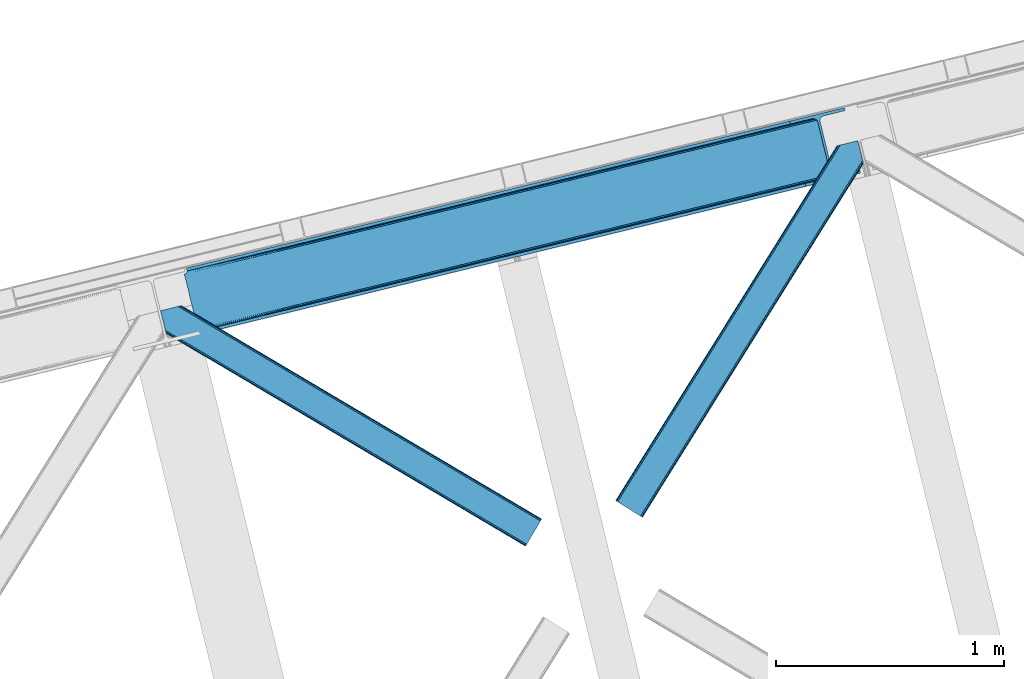
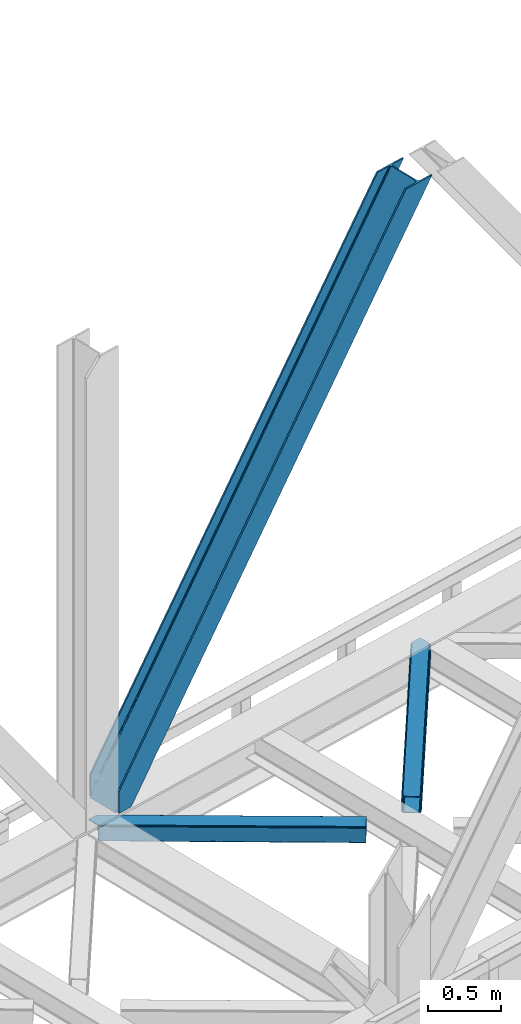
# One storey, part 75 of 92: 3 members.
"""IFC4 building model written with IfcOpenShell, lengths in millimetres."""

from ifc_helpers import new_model, entity, si_unit, converted_unit, derived_unit, direction, frame, origin, place, context, subcontext, project, spatial, triangles, type_object, element, save


model = new_model("IFC4")

# Units and contexts
model_context = context("Model", 3, precision=0.01, world=origin(), true_north=direction((6.12303176911189e-17, 1.0)))
plan_context = context("Plan", 3, precision=0.01, world=origin(), true_north=direction((6.12303176911189e-17, 1.0)))
body_context = subcontext(model_context, "Body", "Model", "MODEL_VIEW")
ifc_project = project(units=[si_unit("LENGTHUNIT", "METRE", prefix="MILLI"), si_unit("AREAUNIT", "SQUARE_METRE"), si_unit("VOLUMEUNIT", "CUBIC_METRE"), converted_unit("PLANEANGLEUNIT", "DEGREE", entity("IfcRatioMeasure", 0.0174532925199433), si_unit("PLANEANGLEUNIT", "RADIAN"), dimensions=[0, 0, 0, 0, 0, 0, 0]), si_unit("MASSUNIT", "GRAM", prefix="KILO"), derived_unit("MASSDENSITYUNIT", [(si_unit("MASSUNIT", "GRAM", prefix="KILO"), 1), (si_unit("LENGTHUNIT", "METRE"), -3)]), derived_unit("MOMENTOFINERTIAUNIT", [(si_unit("LENGTHUNIT", "METRE"), 4)]), si_unit("TIMEUNIT", "SECOND"), si_unit("FREQUENCYUNIT", "HERTZ"), si_unit("THERMODYNAMICTEMPERATUREUNIT", "DEGREE_CELSIUS"), derived_unit("THERMALTRANSMITTANCEUNIT", [(si_unit("MASSUNIT", "GRAM", prefix="KILO"), 1), (si_unit("THERMODYNAMICTEMPERATUREUNIT", "KELVIN"), -1), (si_unit("TIMEUNIT", "SECOND"), -3)]), derived_unit("VOLUMETRICFLOWRATEUNIT", [(si_unit("LENGTHUNIT", "METRE"), 3), (si_unit("TIMEUNIT", "SECOND"), -1)]), derived_unit("MASSFLOWRATEUNIT", [(si_unit("MASSUNIT", "GRAM", prefix="KILO"), 1), (si_unit("TIMEUNIT", "SECOND"), -1)]), derived_unit("ROTATIONALFREQUENCYUNIT", [(si_unit("TIMEUNIT", "SECOND"), -1)]), si_unit("ELECTRICCURRENTUNIT", "AMPERE"), si_unit("ELECTRICVOLTAGEUNIT", "VOLT"), si_unit("POWERUNIT", "WATT"), si_unit("FORCEUNIT", "NEWTON", prefix="KILO"), si_unit("ILLUMINANCEUNIT", "LUX"), si_unit("LUMINOUSFLUXUNIT", "LUMEN"), si_unit("LUMINOUSINTENSITYUNIT", "CANDELA"), derived_unit("USERDEFINED", [(si_unit("MASSUNIT", "GRAM", prefix="KILO"), -1), (si_unit("LENGTHUNIT", "METRE"), -2), (si_unit("TIMEUNIT", "SECOND"), 3), (si_unit("LUMINOUSFLUXUNIT", "LUMEN"), 1)]), derived_unit("LINEARVELOCITYUNIT", [(si_unit("LENGTHUNIT", "METRE"), 1), (si_unit("TIMEUNIT", "SECOND"), -1)]), si_unit("PRESSUREUNIT", "PASCAL"), derived_unit("USERDEFINED", [(si_unit("LENGTHUNIT", "METRE"), -2), (si_unit("MASSUNIT", "GRAM", prefix="KILO"), 1), (si_unit("TIMEUNIT", "SECOND"), -2)]), derived_unit("LINEARFORCEUNIT", [(si_unit("MASSUNIT", "GRAM", prefix="KILO"), 1), (si_unit("LENGTHUNIT", "METRE"), 1), (si_unit("TIMEUNIT", "SECOND"), -2), (si_unit("LENGTHUNIT", "METRE"), -1)]), derived_unit("PLANARFORCEUNIT", [(si_unit("MASSUNIT", "GRAM", prefix="KILO"), 1), (si_unit("LENGTHUNIT", "METRE"), 1), (si_unit("TIMEUNIT", "SECOND"), -2), (si_unit("LENGTHUNIT", "METRE"), -2)])], contexts=[model_context, plan_context])

# Site, building, storey
site_placement = place(None, origin())
site = spatial("IfcSite", under=ifc_project, at=site_placement, CompositionType="ELEMENT")
building_placement = place(site_placement, origin())
building = spatial("IfcBuilding", under=site, at=building_placement, CompositionType="ELEMENT")
storey_placement = place(building_placement, frame((0.0, 0.0, 15900.0)))
storey = spatial("IfcBuildingStorey", under=building, at=storey_placement, Name="05", CompositionType="ELEMENT", Elevation=15900.0)

# Members
member_type_1 = type_object("IfcMemberType", PredefinedType="BRACE")
member_1_placement = place(storey_placement, frame((-17772.45, 16327.86, 3695.0)))
element("IfcMember", 1, at=member_1_placement, inside=storey, type_object=member_type_1, ObjectType="Steel Vertical Brace", PredefinedType="BRACE", context=body_context, shape_type="Tessellation", body=[
    triangles([(58.5487518310547, 26.6239562988285, 0.0), (60.4428222656243, 18.8523376464855, 0.0), (59.1045318603501, 19.6697296142574, 0.80925292968459), (58.9696563720681, 18.4930572509766, 1.10690917968532), (64.089111328125, 19.7406555175785, 8.31577148437282), (64.089111328125, 19.7406555175785, 0.0), (522.90412902832, 126.715521240234, 658.855133056641), (68.377221679686, 19.9243652343757, 14.8293273925774), (72.4072082519524, 18.4523620605469, 22.4381652832017), (524.58542175293, 133.136059570314, 656.552947998047), (73.9838562011719, 17.2861541748043, 26.4425720214822), (2834.75371398926, 696.263314819336, 3911.00081176758), (2834.77231750488, 703.358230590822, 3911.00081176758), (2385.95203857422, 593.953280639647, 3278.7231262207), (2386.50781860352, 586.99905395508, 3279.53005371094), (2831.44228820801, 689.446289062502, 3911.00081176758), (2384.82652587891, 580.578515625, 3281.83223876953), (2825.34033508301, 683.941973876952, 3911.00081176758), (2381.17326049805, 575.671838378907, 3285.27854003906), (2817.37686767578, 680.591015625001, 3911.00081176758), (2376.0933380127, 573.023162841799, 3289.34108276367), (514.170941162109, 119.160168457032, 666.36397705078), (519.250863647459, 121.80884399414, 662.301434326171), (77.0987823486321, 12.6189971923832, 50.6410949707024), (76.5662567138679, 13.8991516113292, 38.6743835449197), (75.4046997070291, 15.4258026123043, 33.1630920410134), (524.029641723631, 140.090286254885, 655.74602050781), (990.06514892578, 246.601226806642, 1312.29896850586), (989.509368896484, 253.55545349121, 1311.48971557617), (1455.54603881836, 360.067556762695, 1968.04266357422), (1454.99025878906, 367.021783447266, 1967.23341064453), (1921.02692871094, 473.532723999024, 2623.78635864258), (1920.47114868164, 480.486950683595, 2622.97710571289), (988.385018920897, 240.180688476563, 1314.598828125), (1453.86590881348, 353.647018432619, 1970.34484863281), (1919.34563598633, 467.113348388672, 2626.08854370117), (984.73175354004, 235.274011230469, 1318.04512939453), (1450.21264343262, 348.740341186525, 1973.78882446289), (1915.69237060547, 462.20550842285, 2629.53251953125), (979.651831054685, 232.626498413085, 1322.10767211914), (1445.13272094727, 346.091665649414, 1977.85369262695), (1910.61361083984, 459.55799560547, 2633.59738769531), (77.0987823486321, 12.6189971923832, 182.433050537107), (2723.82443847656, 657.786593627929, 3911.00081176758), (75.5709686279297, 15.550213623048, 0.0), (77.3813232421853, 11.6585906982418, 0.0), (77.3813232421853, 11.6585906982418, 182.495837402341), (68.377221679686, 19.9243652343757, 0.0), (72.4072082519524, 18.4523620605469, 0.0), (2726.9033203125, 645.155969238282, 3911.00081176758), (80.223010253907, 0.0, 182.495837402341), (80.223010253907, 0.0, 0.0), (191.325531005859, 27.0820678710934, 0.0), (2967.55374755859, 703.817504882814, 3911.00081176758), (1399.80990600586, 593.392849731446, 1967.23341064453), (2779.59196472168, 929.729296874999, 3911.00081176758), (2330.77052307129, 820.324346923828, 3278.7231262207), (1865.29079589844, 706.859179687499, 2622.97710571289), (934.329016113279, 479.927682495118, 1311.48971557617), (468.848126220702, 366.461352539061, 655.74602050781), (3.36839904784938, 252.996185302736, 0.0), (2964.47486572266, 716.448129272461, 3911.00081176758), (188.24664916992, 39.7126922607422, 0.0), (2870.92243652344, 693.643707275392, 3911.00081176758), (94.6942199707009, 16.9082702636715, 0.0), (2862.31133422851, 692.954214477539, 3911.00081176758), (86.083117675782, 16.2187774658214, 0.0), (2854.36065673828, 695.031994628907, 3911.00081176758), (78.1324401855454, 18.2977203369137, 0.0), (2848.28312072754, 699.561950683596, 3911.00081176758), (72.0549041748054, 22.8265136718746, 0.0), (2845.00192565918, 705.851101684571, 3911.00081176758), (68.7737091064446, 29.1168273925778, 0.0), (2789.82157287598, 932.223330688475, 3911.00081176758), (13.5933563232429, 255.487893676758, 0.0), (2789.83901367187, 939.318246459961, 3911.00081176758), (13.611959838865, 262.582809448244, 0.0), (2793.15160217285, 946.135272216796, 3911.00081176758), (16.9233856201172, 269.400997924806, 0.0), (2799.25355529785, 951.639587402346, 3911.00081176758), (23.0253387451157, 274.904150390625, 0.0), (2807.21585998535, 954.990545654297, 3911.00081176758), (30.9876434326179, 278.255108642579, 0.0), (2900.76828918457, 977.794967651369, 3911.00081176758), (124.54123535156, 301.059530639648, 0.0), (2897.69057006836, 990.425592041016, 3911.00081176758), (121.462353515624, 313.690155029299, 0.0), (2770.23323364258, 940.54956665039, 3911.00081176758), (2762.28255615234, 942.627346801759, 3911.00081176758), (2657.04014282226, 931.764056396483, 3911.00081176758), (2753.67145385742, 941.937854003905, 3911.00081176758), (2660.1190246582, 919.133432006836, 3911.00081176758), (2776.31076965332, 936.019610595702, 3911.00081176758), (10.3598327636719, 286.608087158203, 182.495837402341), (10.3598327636719, 286.608087158203, 0.0), (13.2015197753899, 274.94949645996, 182.495837402341), (13.3933685302727, 273.966998291015, 182.433050537107), (1381.42614440918, 607.439666748049, 1977.85369262695), (1846.90703430176, 720.904833984374, 2633.59738769531), (2312.38792419434, 834.37116394043, 3289.34108276367), (915.945254516602, 493.973336791993, 1322.10767211914), (13.3933685302727, 273.966998291015, 50.6410949707024), (450.465527343749, 380.507006835936, 666.36397705078), (13.2015197753899, 274.94949645996, 0.0), (13.509640502929, 272.584524536132, 38.6743835449197), (13.3852294921853, 270.661386108399, 0.0), (13.3852294921853, 270.661386108399, 32.1678039550752), (12.4759826660156, 268.182467651366, 26.1867736816384), (11.9120635986328, 266.629074096682, 22.4381652832017), (11.9120635986328, 266.629074096682, 0.0), (9.01107788085938, 263.467639160155, 14.8293273925774), (9.01107788085938, 263.467639160155, 0.0), (5.11945495605323, 261.6572845459, 8.31577148437282), (5.11945495605323, 261.6572845459, 0.0), (1.4731658935525, 260.767803955079, 0.0), (461.695074462888, 377.818798828126, 658.855133056641), (456.194247436524, 380.49305419922, 662.301434326171), (466.141314697266, 372.892355346679, 656.552947998047), (0.661587524413335, 259.426025390627, 0.80925292968459), (0.0, 260.409686279296, 1.10690917968532), (2318.11664428711, 834.35721130371, 3285.27854003906), (2323.61747131348, 831.681793212892, 3281.83223876953), (2328.06371154785, 826.755349731446, 3279.53005371094), (921.673974609374, 493.959384155272, 1318.04512939453), (1387.15486450195, 607.425714111328, 1973.78882446289), (1852.63575439453, 720.890881347657, 2629.53251953125), (927.175964355469, 491.283966064455, 1314.598828125), (1392.65685424805, 604.750296020507, 1970.34484863281), (1858.1365814209, 718.215463256836, 2626.08854370117), (931.622204589843, 486.357522583008, 1312.29896850586), (1397.10309448242, 599.823852539064, 1968.04266357422), (1862.583984375, 713.28901977539, 2623.78635864258)], [[1, 2, 3], [4, 3, 2], [5, 4, 6], [2, 6, 4], [7, 8, 9], [10, 3, 8], [8, 7, 10], [9, 11, 7], [3, 4, 5], [5, 8, 3], [12, 13, 14], [14, 15, 12], [16, 12, 15], [15, 17, 16], [18, 16, 17], [17, 19, 18], [20, 18, 19], [19, 21, 20], [22, 23, 24], [25, 24, 23], [25, 7, 26], [25, 23, 7], [11, 26, 7], [10, 27, 1], [1, 3, 10], [28, 29, 10], [27, 10, 29], [30, 31, 28], [29, 28, 31], [32, 33, 31], [31, 30, 32], [15, 14, 33], [33, 32, 15], [34, 28, 10], [10, 7, 34], [35, 30, 28], [28, 34, 35], [36, 32, 35], [30, 35, 32], [17, 15, 32], [32, 36, 17], [37, 34, 7], [7, 23, 37], [38, 35, 34], [34, 37, 38], [39, 36, 35], [35, 38, 39], [19, 17, 39], [36, 39, 17], [40, 37, 22], [23, 22, 37], [41, 38, 40], [37, 40, 38], [42, 39, 41], [38, 41, 39], [21, 19, 39], [39, 42, 21], [41, 43, 44], [44, 21, 42], [21, 44, 20], [42, 41, 44], [43, 41, 40], [40, 22, 43], [24, 43, 22], [45, 11, 9], [45, 26, 11], [46, 25, 26], [46, 47, 24], [43, 24, 47], [24, 25, 46], [26, 45, 46], [48, 8, 5], [5, 6, 48], [49, 9, 8], [8, 48, 49], [9, 49, 45], [47, 44, 43], [50, 47, 51], [47, 50, 44], [52, 51, 46], [47, 46, 51], [50, 53, 54], [53, 50, 51], [52, 53, 51], [33, 55, 31], [13, 56, 57], [58, 14, 57], [55, 33, 58], [57, 14, 13], [58, 33, 14], [31, 59, 29], [59, 60, 27], [59, 31, 55], [61, 1, 60], [59, 27, 29], [60, 1, 27], [62, 54, 53], [53, 63, 62], [64, 62, 63], [63, 65, 64], [66, 64, 65], [65, 67, 66], [68, 66, 67], [67, 69, 68], [70, 68, 69], [69, 71, 70], [72, 70, 71], [71, 73, 72], [74, 72, 75], [73, 75, 72], [76, 74, 77], [75, 77, 74], [78, 76, 79], [77, 79, 76], [80, 78, 81], [79, 81, 78], [82, 80, 83], [81, 83, 80], [84, 82, 85], [83, 85, 82], [86, 84, 85], [85, 87, 86], [56, 13, 72], [16, 18, 66], [20, 50, 54], [44, 50, 20], [18, 20, 64], [13, 12, 70], [12, 16, 68], [88, 80, 89], [90, 91, 86], [91, 89, 82], [90, 92, 91], [88, 93, 78], [93, 56, 76], [74, 56, 72], [64, 66, 18], [70, 12, 68], [66, 68, 16], [70, 72, 13], [54, 64, 20], [54, 62, 64], [82, 89, 80], [78, 93, 76], [74, 76, 56], [78, 80, 88], [82, 86, 91], [86, 82, 84], [90, 87, 94], [90, 86, 87], [87, 95, 94], [96, 90, 94], [92, 96, 97], [96, 92, 90], [92, 97, 98], [98, 99, 92], [99, 100, 92], [91, 92, 100], [101, 98, 97], [97, 102, 103], [103, 101, 97], [104, 96, 94], [94, 95, 104], [104, 105, 102], [104, 106, 107], [107, 105, 104], [96, 104, 102], [102, 97, 96], [108, 106, 109], [108, 107, 106], [110, 109, 106], [109, 110, 111], [112, 111, 110], [111, 112, 113], [114, 113, 112], [75, 73, 61], [114, 75, 61], [114, 112, 75], [114, 61, 115], [79, 77, 110], [77, 75, 112], [106, 79, 110], [110, 77, 112], [73, 1, 61], [6, 73, 48], [1, 6, 2], [1, 73, 6], [48, 71, 49], [49, 71, 69], [73, 71, 48], [45, 49, 69], [104, 81, 79], [79, 106, 104], [95, 81, 104], [83, 95, 87], [87, 85, 83], [83, 81, 95], [45, 69, 46], [52, 67, 65], [46, 69, 67], [52, 46, 67], [65, 53, 52], [53, 65, 63], [116, 117, 105], [105, 107, 116], [118, 111, 113], [113, 119, 118], [118, 116, 108], [108, 109, 118], [109, 111, 118], [113, 120, 119], [107, 108, 116], [117, 103, 102], [102, 105, 117], [89, 91, 121], [100, 121, 91], [88, 89, 122], [121, 122, 89], [93, 88, 123], [122, 123, 88], [56, 93, 57], [123, 57, 93], [124, 101, 103], [103, 117, 124], [125, 98, 101], [101, 124, 125], [126, 99, 98], [98, 125, 126], [121, 100, 126], [99, 126, 100], [127, 124, 116], [117, 116, 124], [128, 125, 127], [124, 127, 125], [129, 126, 128], [125, 128, 126], [122, 121, 126], [126, 129, 122], [130, 127, 118], [116, 118, 127], [131, 128, 130], [127, 130, 128], [132, 129, 128], [128, 131, 132], [123, 122, 132], [129, 132, 122], [60, 118, 61], [119, 61, 118], [59, 130, 118], [118, 60, 59], [55, 131, 130], [130, 59, 55], [58, 132, 55], [131, 55, 132], [57, 123, 58], [132, 58, 123], [120, 113, 114], [114, 115, 120], [115, 61, 119], [119, 120, 115]]),
])
member_type_2 = type_object("IfcMemberType", PredefinedType="BRACE")
member_2_placement = place(storey_placement, frame((-15879.74, 15520.97, 3510.0)))
element("IfcMember", 2, at=member_2_placement, inside=storey, type_object=member_type_2, ObjectType="Steel Horizontal Brace", PredefinedType="BRACE", context=body_context, shape_type="Tessellation", body=[
    triangles([(933.020956420898, 1535.69230957031, 0.0), (967.780462646484, 1393.09287414551, 0.0), (14.8444427490231, 64.8704589843746, 0.0), (103.914587402343, 9.2680389404286, 0.0), (928.803771972656, 1552.99241638184, 5.49966430664063), (928.943298339844, 1552.41687011719, 5.20782165527635), (930.803649902344, 1544.78826599121, 1.33247680664135), (971.997647094726, 1375.79393005371, 5.49966430664063), (971.856958007813, 1376.36831359863, 5.20782165527635), (969.997769165038, 1383.99808044434, 1.33247680664135), (972.208099365234, 1375.53813171387, 5.85313110351854), (972.423202514648, 1375.28349609375, 6.20659790039281), (928.911904907227, 1553.57028808594, 5.74383544921875), (972.725509643555, 1375.53929443359, 6.35310058594041), (929.027014160156, 1554.1772277832, 5.9996337890625), (973.026654052734, 1375.79393005371, 6.49960327148438), (929.142123413085, 1554.78416748047, 6.25659484863354), (929.254907226563, 1555.3632019043, 6.49960327148438), (4.34857177734375, 71.4235473632798, 5.12526855468968), (1.13016357421839, 73.4315643310547, 10.8028289794929), (973.360354614257, 1630.84347839356, 10.8028289794929), (976.915951538085, 1631.71086730957, 6.49960327148438), (9.16455688476526, 68.4167541503903, 1.33247680664135), (971.508142089844, 1630.39234313965, 17.5000946044929), (0.0, 74.1373352050778, 17.5000946044929), (1081.10145263672, 1548.91824645996, 6.49960327148438), (1056.20878601074, 1651.03875732422, 6.49960327148438), (971.508142089844, 1630.39234313965, 122.500662231447), (0.0, 74.1373352050778, 122.500662231447), (973.360354614257, 1630.84347839356, 129.197927856447), (1.13016357421839, 73.4315643310547, 129.197927856447), (978.633288574218, 1632.12944641113, 134.874325561526), (4.34857177734375, 71.4235473632798, 134.874325561526), (986.526992797852, 1634.05374755859, 138.667117309571), (9.16455688476526, 68.4167541503903, 138.667117309571), (995.840377807617, 1636.32337646484, 139.999594116212), (14.8444427490231, 64.8704589843746, 139.999594116212), (118.757867431641, 0.0, 17.5000946044929), (117.628866577148, 0.705770874023074, 10.8028289794929), (1085.14190368652, 1551.25182495117, 10.9783996582046), (1087.41734619141, 1552.56569824219, 13.5003387451179), (109.594473266601, 5.72174377441297, 1.33247680664135), (114.410458374023, 2.71495056152344, 5.12526855468968), (1087.56966247559, 1551.93550415039, 17.5000946044929), (1081.77699279785, 1575.70265808105, 139.999594116212), (1063.00837097168, 1652.6967956543, 139.999594116212), (103.914587402343, 9.2680389404286, 139.999594116212), (1083.99429931641, 1566.60786437988, 138.667117309571), (109.594473266601, 5.72174377441297, 138.667117309571), (1085.87325439453, 1558.89670715332, 134.874325561526), (114.410458374023, 2.71495056152344, 134.874325561526), (1087.12899169922, 1553.74469604492, 129.197927856447), (117.628866577148, 0.705770874023074, 129.197927856447), (1087.56966247559, 1551.93550415039, 122.500662231447), (118.757867431641, 0.0, 122.500662231447), (1082.5362487793, 1566.77413330078, 12.1260040283232), (1083.96523132324, 1566.72529907227, 13.5003387451179), (1077.85165100098, 1569.98672790527, 8.3320495605476), (1074.64603271484, 1577.50138549805, 6.99957275390625), (1056.69131469727, 1651.1561920166, 6.99957275390625), (1005.57350463867, 1638.69648742676, 6.99957275390625), (20.7836151123047, 61.163708496093, 6.99957275390625), (97.9789031982418, 12.9759521484375, 6.99957275390625), (108.475936889648, 6.42286376953052, 12.1260040283232), (111.694345092774, 4.41368408203016, 17.8035644531265), (1084.81169128418, 1563.25225524902, 17.8035644531265), (103.659951782227, 9.42849426269458, 8.3320495605476), (1085.25236206055, 1561.44306335449, 24.4996673583992), (112.823345947265, 3.70791320800708, 24.4996673583992), (983.093481445312, 1633.21658935547, 17.8035644531265), (981.241268920898, 1632.76429138183, 24.4996673583992), (7.0693359375, 69.7248138427731, 17.8035644531265), (5.94033508300708, 70.4305847167961, 24.4996673583992), (988.366415405273, 1634.50139465332, 12.1260040283232), (10.2877441406254, 67.716796875, 12.1260040283232), (996.260119628905, 1636.42569580078, 8.3320495605476), (15.1037292480469, 64.7100036621086, 8.3320495605476), (981.241268920898, 1632.76429138183, 115.501089477541), (5.94033508300708, 70.4305847167961, 115.501089477541), (996.260119628905, 1636.42569580078, 131.667544555665), (1005.57350463867, 1638.69648742676, 133.000021362306), (1063.00837097168, 1652.6967956543, 133.000021362306), (988.366415405273, 1634.50139465332, 127.87475280762), (983.093481445312, 1633.21658935547, 122.196029663086), (20.7836151123047, 61.163708496093, 133.000021362306), (15.1037292480469, 64.7100036621086, 131.667544555665), (10.2877441406254, 67.716796875, 127.87475280762), (7.0693359375, 69.7248138427731, 122.196029663086), (108.475936889648, 6.42286376953052, 127.87475280762), (111.694345092774, 4.41368408203016, 122.196029663086), (112.823345947265, 3.70791320800708, 115.501089477541), (97.9789031982418, 12.9759521484375, 133.000021362306), (103.659951782227, 9.42849426269458, 131.667544555665), (1085.25236206055, 1561.44306335449, 115.501089477541), (1084.81169128418, 1563.25225524902, 122.196029663086), (1083.55595397949, 1568.40426635742, 127.87475280762), (1081.67699890137, 1576.11426086426, 131.667544555665), (1079.45969238281, 1585.20905456543, 133.000021362306)], [[1, 2, 3], [4, 3, 2], [1, 5, 2], [6, 5, 1], [1, 7, 6], [2, 5, 8], [8, 9, 2], [10, 2, 9], [11, 8, 5], [12, 11, 13], [14, 12, 15], [16, 14, 17], [17, 18, 16], [15, 17, 14], [13, 15, 12], [5, 13, 11], [17, 19, 18], [19, 17, 15], [13, 19, 15], [19, 13, 5], [5, 6, 19], [20, 21, 18], [18, 19, 20], [21, 22, 18], [19, 6, 7], [7, 1, 23], [3, 23, 1], [7, 23, 19], [24, 21, 20], [20, 25, 24], [18, 26, 16], [26, 18, 22], [27, 26, 22], [28, 24, 29], [25, 29, 24], [30, 28, 31], [29, 31, 28], [32, 30, 33], [31, 33, 30], [34, 32, 35], [33, 35, 32], [36, 34, 37], [35, 37, 34], [38, 39, 40], [40, 41, 38], [42, 10, 9], [39, 12, 16], [16, 40, 39], [16, 26, 40], [9, 39, 43], [9, 12, 39], [9, 43, 42], [2, 10, 4], [42, 4, 10], [41, 44, 38], [45, 36, 37], [36, 45, 46], [37, 47, 45], [48, 45, 47], [47, 49, 48], [50, 48, 49], [49, 51, 50], [52, 50, 51], [51, 53, 52], [54, 52, 53], [53, 55, 54], [44, 54, 38], [55, 38, 54], [56, 40, 26], [41, 40, 56], [56, 57, 41], [58, 26, 59], [26, 58, 56], [60, 59, 26], [59, 61, 62], [61, 59, 60], [62, 63, 59], [64, 65, 66], [66, 57, 64], [58, 59, 63], [63, 67, 58], [56, 58, 67], [67, 64, 56], [57, 56, 64], [68, 66, 65], [65, 69, 68], [70, 71, 72], [73, 72, 71], [74, 70, 75], [72, 75, 70], [76, 74, 77], [75, 77, 74], [61, 76, 62], [77, 62, 76], [71, 78, 79], [79, 73, 71], [34, 36, 80], [46, 81, 36], [81, 46, 82], [81, 80, 36], [83, 34, 80], [83, 32, 34], [32, 84, 30], [84, 32, 83], [28, 84, 78], [84, 28, 30], [61, 22, 76], [70, 74, 22], [74, 76, 22], [61, 60, 22], [71, 70, 24], [21, 24, 70], [28, 71, 24], [71, 28, 78], [70, 22, 21], [80, 81, 85], [85, 86, 80], [83, 80, 86], [86, 87, 83], [84, 83, 87], [87, 88, 84], [78, 84, 88], [88, 79, 78], [53, 89, 90], [91, 38, 55], [53, 90, 55], [53, 51, 89], [90, 91, 55], [89, 51, 49], [92, 47, 37], [47, 93, 49], [93, 47, 92], [93, 89, 49], [39, 64, 43], [69, 38, 91], [38, 65, 39], [65, 38, 69], [39, 65, 64], [4, 63, 3], [42, 43, 64], [64, 67, 42], [67, 63, 4], [4, 42, 67], [87, 35, 33], [37, 85, 92], [37, 86, 85], [86, 37, 35], [87, 86, 35], [79, 29, 25], [31, 88, 87], [33, 31, 87], [88, 31, 29], [79, 88, 29], [23, 75, 19], [3, 63, 62], [62, 77, 3], [77, 75, 23], [23, 3, 77], [20, 19, 75], [25, 73, 79], [72, 25, 20], [25, 72, 73], [72, 20, 75], [66, 41, 57], [54, 44, 68], [44, 66, 68], [68, 94, 54], [44, 41, 66], [95, 54, 94], [52, 54, 95], [50, 95, 96], [95, 50, 52], [96, 48, 50], [97, 48, 96], [97, 98, 45], [97, 45, 48], [98, 46, 45], [98, 82, 46], [81, 98, 85], [81, 82, 98], [92, 85, 98], [95, 94, 90], [91, 90, 94], [96, 95, 89], [90, 89, 95], [97, 96, 93], [89, 93, 96], [98, 97, 92], [93, 92, 97], [94, 68, 69], [69, 91, 94]]),
])
member_type_3 = type_object("IfcMemberType", PredefinedType="BRACE")
member_3_placement = place(storey_placement, frame((-17875.18, 15394.15, 3510.0)))
element("IfcMember", 3, at=member_3_placement, inside=storey, type_object=member_type_3, ObjectType="Steel Horizontal Brace", PredefinedType="BRACE", context=body_context, shape_type="Tessellation", body=[
    triangles([(1672.2107208252, 120.470553588868, 122.500662231447), (1672.2107208252, 120.470553588868, 17.5000946044929), (91.5002288818359, 1056.29133911133, 17.5000946044929), (91.5002288818359, 1056.29133911133, 122.500662231447), (1663.29614868164, 105.412170410156, 139.999594116212), (1666.70756835938, 111.174609375001, 138.667117309571), (76.4767272949211, 1052.62877197266, 138.667117309571), (67.1679931640647, 1050.36030578613, 139.999594116212), (1669.59925231934, 116.060357666016, 134.874325561526), (84.3704315185569, 1054.55307312012, 134.874325561526), (1671.53285522461, 119.325274658204, 129.197927856447), (89.6480163574233, 1055.84020385742, 129.197927856447), (18.767459106446, 956.993911743164, 139.999594116212), (1609.80406494141, 15.0595458984371, 139.999594116212), (0.0, 1033.98688659668, 139.999594116212), (1600.89065551758, 0.0, 122.500662231447), (1601.56852111816, 1.14644165039135, 129.197927856447), (24.5612915039055, 933.226757812499, 122.500662231447), (24.1194580078118, 935.035949707031, 129.197927856447), (1603.50096130371, 4.4113586425774, 134.874325561526), (22.8637207031243, 940.18796081543, 134.874325561526), (1606.3938079834, 9.29594421386719, 138.667117309571), (20.9847656250022, 947.897955322265, 138.667117309571), (1600.89065551758, 0.0, 17.5000946044929), (24.5612915039055, 933.226757812499, 17.5000946044929), (1671.53285522461, 119.325274658204, 10.8028289794929), (89.5573242187493, 1055.81811218262, 10.8167816162131), (162.736578369142, 1012.4207611084, 10.5005218505867), (1669.59925231934, 116.060357666016, 5.12526855468968), (165.152709960938, 1006.73157348633, 5.12526855468968), (164.09696044922, 1011.0638671875, 9.50058288574292), (163.767910766601, 1011.39175415039, 9.74126586914281), (163.414443969727, 1011.74173278809, 10.0005523681648), (163.060977172852, 1012.09287414551, 10.2586761474631), (89.4666320800789, 1055.79602050781, 10.5005218505867), (1666.70756835938, 111.174609375001, 1.33247680664135), (167.031665039063, 999.021578979493, 1.33247680664135), (1663.29614868164, 105.412170410156, 0.0), (169.248971557619, 989.925622558592, 0.0), (1609.80406494141, 15.0595458984371, 0.0), (204.009640502929, 847.326187133789, 0.0), (166.88748779297, 995.391567993163, 10.5005218505867), (72.0339752197287, 1051.54627990723, 10.5005218505867), (168.582733154297, 992.661502075196, 9.50058288574292), (168.164154052734, 993.333554077148, 9.74591674804833), (167.732785034179, 994.025372314452, 10.0005523681648), (167.304904174805, 994.718353271484, 10.2540252685576), (1666.03667907715, 110.037469482422, 12.1260040283232), (1667.96446838379, 113.301223754883, 17.8035644531265), (79.9148895263679, 1053.46709289551, 17.8035644531265), (1663.14383239746, 105.151721191407, 8.3320495605476), (169.397799682618, 989.317520141602, 8.81690368652562), (74.112918090821, 1052.05322570801, 12.4271484375022), (171.566271972657, 980.419226074218, 6.99957275390625), (1659.72776184082, 99.3881195068352, 6.99957275390625), (1668.64698486328, 114.447665405274, 24.4996673583992), (81.7671020507805, 1053.91939086914, 24.4996673583992), (1668.64698486328, 114.447665405274, 115.501089477541), (81.7671020507805, 1053.91939086914, 115.501089477541), (74.6373046875015, 1052.18112487793, 127.87475280762), (66.7436004638694, 1050.25682373047, 131.667544555665), (79.9148895263679, 1053.46709289551, 122.196029663086), (57.4348663330093, 1047.98835754395, 133.000021362306), (0.0, 1033.98688659668, 133.000021362306), (1667.96446838379, 113.301223754883, 122.196029663086), (1666.03667907715, 110.037469482422, 127.87475280762), (1663.14383239746, 105.151721191407, 131.667544555665), (1659.72776184082, 99.3881195068352, 133.000021362306), (16.4501586914084, 966.50030822754, 133.000021362306), (1613.37245178223, 21.0824340820309, 133.000021362306), (1613.37245178223, 21.0824340820309, 6.99957275390625), (201.692340087891, 856.832583618165, 6.99957275390625), (1607.06818542481, 10.4342468261711, 127.87475280762), (1609.96103210449, 15.3199951171882, 131.667544555665), (1604.45787963867, 6.02405090332104, 115.501089477541), (1605.13574523926, 7.17049255371057, 122.196029663086), (1606.3938079834, 9.29594421386719, 1.33247680664135), (1607.06818542481, 10.4342468261711, 12.1260040283232), (1603.50096130371, 4.4113586425774, 5.12526855468968), (1609.96103210449, 15.3199951171882, 8.3320495605476), (1601.56852111816, 1.14644165039135, 10.8028289794929), (1604.45787963867, 6.02405090332104, 24.4996673583992), (1605.13574523926, 7.17049255371057, 17.8035644531265), (18.6674652099609, 957.405514526366, 131.667544555665), (20.5464202880867, 949.694357299804, 127.87475280762), (21.8021575927742, 944.542346191407, 122.196029663086), (22.2439910888679, 942.733154296875, 115.501089477541), (22.2439910888679, 942.733154296875, 24.4996673583992), (21.7812286376975, 944.628387451172, 17.8163543701194), (21.7602996826172, 944.717916870117, 17.5000946044929), (203.86081237793, 847.934289550782, 8.81690368652562), (206.225784301758, 838.23023071289, 1.33247680664135), (204.675878906251, 844.591470336914, 9.50058288574292), (208.105902099611, 830.520236206055, 5.12526855468968), (209.161651611328, 826.187942504883, 9.50058288574292), (204.682855224612, 843.327593994141, 10.2075164794951), (204.323574829101, 843.305502319336, 10.3540191650391), (203.965457153321, 843.284573364257, 10.5005218505867), (27.0088165283196, 945.866683959961, 12.1260040283232), (28.3459442138665, 947.254971313476, 10.5005218505867), (204.677041625979, 843.958950805663, 9.85404968261719), (32.132922363282, 930.36181640625, 10.8179443359404), (209.130258178713, 825.982141113282, 9.88311767578125), (208.116366577149, 826.255380249024, 10.5005218505867), (208.802371215821, 826.071670532227, 10.0842681884787), (32.4968536376946, 930.225778198243, 10.5005218505867)], [[1, 2, 3], [3, 4, 1], [5, 6, 7], [7, 8, 5], [6, 9, 10], [10, 7, 6], [9, 11, 12], [12, 10, 9], [11, 1, 4], [4, 12, 11], [5, 13, 14], [13, 5, 8], [15, 13, 8], [16, 17, 18], [19, 18, 17], [17, 20, 19], [21, 19, 20], [20, 22, 21], [23, 21, 22], [22, 14, 23], [13, 23, 14], [24, 16, 18], [18, 25, 24], [26, 27, 3], [27, 26, 28], [26, 29, 30], [30, 31, 26], [26, 32, 33], [32, 26, 31], [26, 34, 28], [34, 26, 33], [28, 35, 27], [29, 36, 37], [37, 30, 29], [36, 38, 39], [39, 37, 36], [3, 2, 26], [38, 40, 41], [41, 39, 38], [28, 42, 35], [43, 35, 42], [31, 44, 45], [45, 32, 31], [32, 45, 46], [46, 33, 32], [33, 46, 47], [47, 34, 33], [34, 47, 42], [42, 28, 34], [48, 49, 50], [45, 51, 46], [45, 44, 51], [42, 47, 51], [47, 46, 51], [44, 52, 51], [48, 53, 42], [42, 51, 48], [53, 43, 42], [51, 52, 54], [54, 55, 51], [50, 53, 48], [49, 56, 57], [57, 50, 49], [56, 58, 59], [59, 57, 56], [60, 61, 7], [10, 60, 7], [10, 12, 62], [60, 10, 62], [62, 12, 4], [61, 8, 7], [15, 63, 64], [15, 8, 63], [61, 63, 8], [62, 4, 59], [57, 3, 50], [4, 57, 59], [3, 27, 50], [4, 3, 57], [35, 50, 27], [35, 53, 50], [35, 43, 53], [58, 65, 59], [62, 59, 65], [65, 66, 62], [60, 62, 66], [66, 67, 60], [61, 60, 67], [67, 68, 61], [63, 61, 68], [68, 69, 63], [68, 70, 69], [69, 64, 63], [71, 55, 72], [54, 72, 55], [11, 66, 65], [58, 2, 1], [11, 65, 1], [11, 9, 66], [65, 58, 1], [66, 9, 6], [68, 5, 14], [5, 67, 6], [67, 5, 68], [67, 66, 6], [26, 48, 29], [56, 2, 58], [2, 49, 26], [49, 2, 56], [26, 49, 48], [38, 55, 40], [36, 29, 48], [48, 51, 36], [51, 55, 38], [38, 36, 51], [73, 22, 20], [14, 70, 68], [14, 74, 70], [74, 14, 22], [73, 74, 22], [75, 16, 24], [17, 76, 73], [20, 17, 73], [76, 17, 16], [75, 76, 16], [77, 78, 79], [40, 55, 71], [71, 80, 40], [80, 78, 77], [77, 40, 80], [81, 79, 78], [24, 82, 75], [83, 24, 81], [24, 83, 82], [83, 81, 78], [70, 74, 84], [84, 69, 70], [74, 73, 85], [85, 84, 74], [73, 76, 86], [86, 85, 73], [76, 75, 87], [87, 86, 76], [75, 82, 87], [88, 87, 82], [86, 87, 18], [18, 19, 86], [21, 86, 19], [86, 21, 85], [18, 88, 25], [89, 90, 25], [25, 88, 89], [87, 88, 18], [84, 23, 13], [15, 69, 13], [64, 69, 15], [84, 85, 23], [23, 85, 21], [69, 84, 13], [44, 30, 37], [39, 44, 37], [54, 52, 39], [54, 39, 72], [30, 44, 31], [39, 52, 44], [72, 41, 91], [41, 92, 93], [41, 72, 39], [94, 93, 92], [41, 93, 91], [94, 95, 93], [83, 89, 88], [71, 72, 91], [78, 96, 97], [97, 98, 78], [98, 99, 78], [98, 100, 99], [80, 91, 93], [93, 78, 80], [78, 93, 101], [101, 96, 78], [83, 78, 99], [99, 90, 83], [90, 89, 83], [91, 80, 71], [88, 82, 83], [24, 25, 102], [79, 103, 95], [81, 102, 104], [104, 79, 81], [104, 105, 79], [95, 94, 79], [40, 77, 92], [92, 41, 40], [77, 79, 94], [94, 92, 77], [106, 81, 24], [99, 106, 25], [99, 100, 106], [25, 90, 99], [98, 104, 106], [106, 100, 98]]),
])

save(model, "model.ifc")
